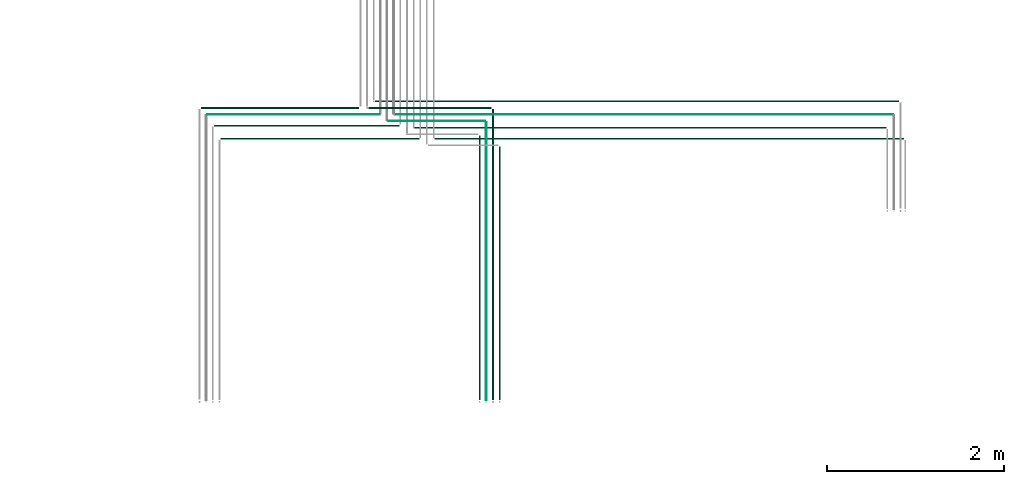
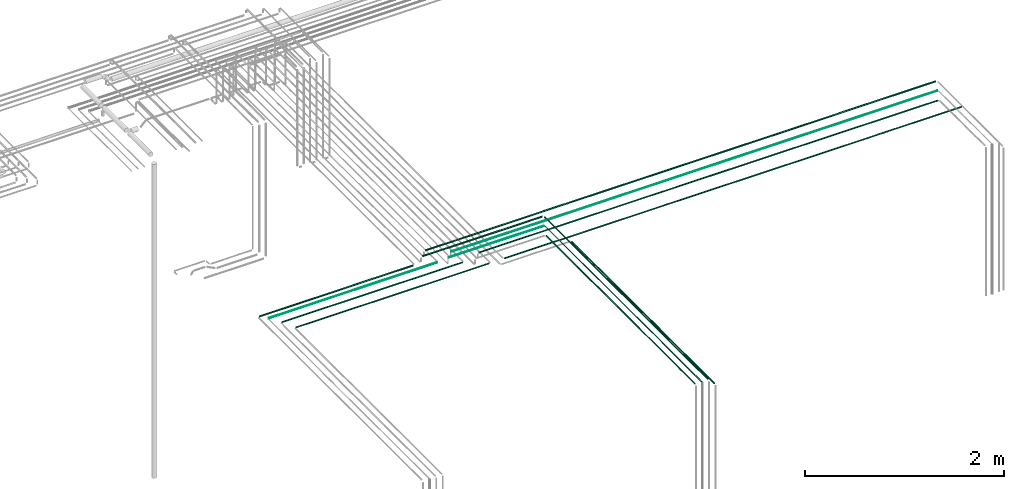
# One storey, part 22 of 65: 14 flow segments.
"""IFC2X3 building model written with IfcOpenShell, lengths in millimetres."""

from ifc_helpers import new_model, entity, si_unit, converted_unit, derived_unit, direction, frame, frame_2d, origin, origin_2d_with_axis, place, context, subcontext, project, spatial, circle, extrude, type_object, element, save


model = new_model("IFC2X3")

# Units and contexts
model_context = context("Model", 3, precision=0.01, world=origin(), true_north=direction((6.12303176911189e-17, 1.0)))
body_context = subcontext(model_context, "Body", "Model", "MODEL_VIEW")
ifc_project = project(units=[si_unit("LENGTHUNIT", "METRE", prefix="MILLI"), si_unit("AREAUNIT", "SQUARE_METRE"), si_unit("VOLUMEUNIT", "CUBIC_METRE"), converted_unit("PLANEANGLEUNIT", "DEGREE", entity("IfcRatioMeasure", 0.0174532925199433), si_unit("PLANEANGLEUNIT", "RADIAN"), dimensions=[0, 0, 0, 0, 0, 0, 0]), si_unit("MASSUNIT", "GRAM", prefix="KILO"), derived_unit("MASSDENSITYUNIT", [(si_unit("MASSUNIT", "GRAM", prefix="KILO"), 1), (si_unit("LENGTHUNIT", "METRE"), -3)]), derived_unit("MOMENTOFINERTIAUNIT", [(si_unit("LENGTHUNIT", "METRE"), 4)]), si_unit("TIMEUNIT", "SECOND"), si_unit("FREQUENCYUNIT", "HERTZ"), si_unit("THERMODYNAMICTEMPERATUREUNIT", "DEGREE_CELSIUS"), derived_unit("THERMALTRANSMITTANCEUNIT", [(si_unit("MASSUNIT", "GRAM", prefix="KILO"), 1), (si_unit("THERMODYNAMICTEMPERATUREUNIT", "KELVIN"), -1), (si_unit("TIMEUNIT", "SECOND"), -3)]), derived_unit("VOLUMETRICFLOWRATEUNIT", [(si_unit("LENGTHUNIT", "METRE"), 3), (si_unit("TIMEUNIT", "SECOND"), -1)]), derived_unit("MASSFLOWRATEUNIT", [(si_unit("MASSUNIT", "GRAM", prefix="KILO"), 1), (si_unit("TIMEUNIT", "SECOND"), -1)]), derived_unit("ROTATIONALFREQUENCYUNIT", [(si_unit("TIMEUNIT", "SECOND"), -1)]), si_unit("ELECTRICCURRENTUNIT", "AMPERE"), si_unit("ELECTRICVOLTAGEUNIT", "VOLT"), si_unit("POWERUNIT", "WATT"), si_unit("FORCEUNIT", "NEWTON", prefix="KILO"), si_unit("ILLUMINANCEUNIT", "LUX"), si_unit("LUMINOUSFLUXUNIT", "LUMEN"), si_unit("LUMINOUSINTENSITYUNIT", "CANDELA"), derived_unit("USERDEFINED", [(si_unit("MASSUNIT", "GRAM", prefix="KILO"), -1), (si_unit("LENGTHUNIT", "METRE"), -2), (si_unit("TIMEUNIT", "SECOND"), 3), (si_unit("LUMINOUSFLUXUNIT", "LUMEN"), 1)]), derived_unit("LINEARVELOCITYUNIT", [(si_unit("LENGTHUNIT", "METRE"), 1), (si_unit("TIMEUNIT", "SECOND"), -1)]), si_unit("PRESSUREUNIT", "PASCAL"), derived_unit("USERDEFINED", [(si_unit("LENGTHUNIT", "METRE"), -2), (si_unit("MASSUNIT", "GRAM", prefix="KILO"), 1), (si_unit("TIMEUNIT", "SECOND"), -2)]), derived_unit("LINEARFORCEUNIT", [(si_unit("MASSUNIT", "GRAM", prefix="KILO"), 1), (si_unit("LENGTHUNIT", "METRE"), 1), (si_unit("TIMEUNIT", "SECOND"), -2), (si_unit("LENGTHUNIT", "METRE"), -1)]), derived_unit("PLANARFORCEUNIT", [(si_unit("MASSUNIT", "GRAM", prefix="KILO"), 1), (si_unit("LENGTHUNIT", "METRE"), 1), (si_unit("TIMEUNIT", "SECOND"), -2), (si_unit("LENGTHUNIT", "METRE"), -2)])], contexts=[model_context])

# Site, building, storey
site_placement = place(None, frame((0.0, -0.00077364408347762, 0.0)))
site = spatial("IfcSite", under=ifc_project, at=site_placement, CompositionType="ELEMENT")
building_placement = place(site_placement, origin())
building = spatial("IfcBuilding", under=site, at=building_placement, CompositionType="ELEMENT")
storey_placement = place(building_placement, frame((0.0, 0.0, 19800.0)))
storey = spatial("IfcBuildingStorey", under=building, at=storey_placement, CompositionType="ELEMENT", Elevation=19800.0)

# Flow segments
pipe_segment_type = type_object("IfcPipeSegmentType", PredefinedType="NOTDEFINED")
flow_segment_1_placement = place(storey_placement, frame((64237.1498843194, 4080.31599040538, 3140.90472776409)))
element("IfcFlowSegment", 1, at=flow_segment_1_placement, inside=storey, type_object=pipe_segment_type, context=body_context, shape_type="SweptSolid", body=[
    extrude(circle(Radius=7.5, at=origin_2d_with_axis()), frame((0.0, 9.0952722359234, 9.09527223591419), z_axis=(1.0, 0.0, 0.0), x_axis=(0.0, -1.0, 0.0)), (0.0, 0.0, 1.0), 1779.96199895821),
])
flow_segment_2_placement = place(storey_placement, frame((66874.1118832777, 3732.83013468698, 3142.40472776415)))
element("IfcFlowSegment", 2, at=flow_segment_2_placement, inside=storey, type_object=pipe_segment_type, context=body_context, shape_type="SweptSolid", body=[
    extrude(circle(Radius=6.0, at=frame_2d((4.33146851719357e-12, 0.0), x_axis=(1.0, 0.0))), frame((0.0, 7.59527223592049, 7.59527223591454), z_axis=(1.0, 0.0, 0.0), x_axis=(0.0, 1.0, 0.0)), (0.0, 0.0, 1.0), 5294.03800104174),
])
flow_segment_3_placement = place(storey_placement, frame((66203.1118832776, 4155.31599040536, 3215.90472776409)))
element("IfcFlowSegment", 3, at=flow_segment_3_placement, inside=storey, type_object=pipe_segment_type, context=body_context, shape_type="SweptSolid", body=[
    extrude(circle(Radius=7.5, at=frame_2d((1.29944055515807e-11, 0.0), x_axis=(1.0, 0.0))), frame((0.0, 9.09527223592881, 9.09527223591419), z_axis=(1.0, 0.0, 0.0), x_axis=(0.0, 1.0, 0.0)), (0.0, 0.0, 1.0), 5908.28250962337),
])
flow_segment_4_placement = place(storey_placement, frame((66128.1118832776, 4080.31599040536, 3215.90472776409)))
element("IfcFlowSegment", 4, at=flow_segment_4_placement, inside=storey, type_object=pipe_segment_type, context=body_context, shape_type="SweptSolid", body=[
    extrude(circle(Radius=7.5, at=frame_2d((8.12150346973795e-12, 0.0), x_axis=(1.0, 0.0))), frame((0.0, 9.09527223592394, 9.09527223591419), z_axis=(1.0, 0.0, 0.0), x_axis=(0.0, 1.0, 0.0)), (0.0, 0.0, 1.0), 1383.28250962336),
])
flow_segment_5_placement = place(storey_placement, frame((67520.2991206651, 794.55544271603, 3215.90472776409)))
element("IfcFlowSegment", 5, at=flow_segment_5_placement, inside=storey, type_object=pipe_segment_type, context=body_context, shape_type="SweptSolid", body=[
    extrude(circle(Radius=7.5, at=frame_2d((8.66293703438714e-12, 0.0), x_axis=(1.0, 0.0))), frame((9.09527223592286, 0.0, 9.09527223591419), z_axis=(0.0, 1.0, 0.0), x_axis=(-1.0, 0.0, 0.0)), (0.0, 0.0, 1.0), 3276.85581992526),
])
flow_segment_6_placement = place(storey_placement, frame((64304.1498843194, 4008.81599040537, 3144.40472776408)))
element("IfcFlowSegment", 6, at=flow_segment_6_placement, inside=storey, type_object=pipe_segment_type, context=body_context, shape_type="SweptSolid", body=[
    extrude(circle(Radius=4.0, at=frame_2d((-7.58006990508875e-12, 0.0), x_axis=(1.0, 0.0))), frame((0.0, 5.59527223592365, 5.59527223591499), z_axis=(1.0, 0.0, 0.0), x_axis=(0.0, 1.0, 0.0)), (0.0, 0.0, 1.0), 1945.96199895822),
])
flow_segment_7_placement = place(storey_placement, frame((66420.1118832776, 4008.81599040536, 3219.40472776408)))
element("IfcFlowSegment", 7, at=flow_segment_7_placement, inside=storey, type_object=pipe_segment_type, context=body_context, shape_type="SweptSolid", body=[
    extrude(circle(Radius=4.0, at=frame_2d((1.57015733748267e-11, 0.0), x_axis=(1.0, 0.0))), frame((0.0, 5.59527223593178, 5.59527223591499), z_axis=(1.0, 0.0, 0.0), x_axis=(0.0, 1.0, 0.0)), (0.0, 0.0, 1.0), 5624.28250962336),
])
flow_segment_8_placement = place(storey_placement, frame((66345.1118832776, 3933.81599040536, 3219.40472776409)))
element("IfcFlowSegment", 8, at=flow_segment_8_placement, inside=storey, type_object=pipe_segment_type, context=body_context, shape_type="SweptSolid", body=[
    extrude(circle(Radius=4.0, at=frame_2d((1.08286712929839e-11, 0.0), x_axis=(1.0, 0.0))), frame((0.0, 5.59527223592636, 5.59527223591499), z_axis=(1.0, 0.0, 0.0), x_axis=(0.0, 1.0, 0.0)), (0.0, 0.0, 1.0), 1099.28250962337),
])
flow_segment_9_placement = place(storey_placement, frame((67448.7991206651, 788.555442716031, 3219.40472776409)))
element("IfcFlowSegment", 9, at=flow_segment_9_placement, inside=storey, type_object=pipe_segment_type, context=body_context, shape_type="SweptSolid", body=[
    extrude(circle(Radius=4.0, at=frame_2d((8.66293703438714e-12, 0.0), x_axis=(1.0, 0.0))), frame((5.59527223592365, 0.0, 5.59527223591499), z_axis=(0.0, 1.0, 0.0), x_axis=(-1.0, 0.0, 0.0)), (0.0, 0.0, 1.0), 3140.85581992527),
])
flow_segment_10_placement = place(storey_placement, frame((66649.1118832777, 3856.81599040537, 3217.40472776409)))
element("IfcFlowSegment", 10, at=flow_segment_10_placement, inside=storey, type_object=pipe_segment_type, context=body_context, shape_type="SweptSolid", body=[
    extrude(circle(Radius=6.0, at=frame_2d((1.84087411980727e-11, 0.0), x_axis=(1.0, 0.0))), frame((0.0, 7.59527223593457, 7.59527223591454), z_axis=(1.0, 0.0, 0.0), x_axis=(0.0, 1.0, 0.0)), (0.0, 0.0, 1.0), 5316.2825096233),
])
flow_segment_11_placement = place(storey_placement, frame((67371.7991206651, 794.55544271603, 3217.40472776409)))
element("IfcFlowSegment", 11, at=flow_segment_11_placement, inside=storey, type_object=pipe_segment_type, context=body_context, shape_type="SweptSolid", body=[
    extrude(circle(Radius=6.0, at=frame_2d((8.66293703438714e-12, 0.0), x_axis=(1.0, 0.0))), frame((7.59527223593186, 0.0, 7.59527223591454), z_axis=(0.0, 1.0, 0.0), x_axis=(-1.0, 0.0, 0.0)), (0.0, 0.0, 1.0), 2980.85581992527),
])
flow_segment_12_placement = place(storey_placement, frame((64383.1498843194, 3881.81599040537, 3142.40472776409)))
element("IfcFlowSegment", 12, at=flow_segment_12_placement, inside=storey, type_object=pipe_segment_type, context=body_context, shape_type="SweptSolid", body=[
    extrude(circle(Radius=6.0, at=frame_2d((-1.19115384222823e-11, 0.0), x_axis=(1.0, 0.0))), frame((0.0, 7.59527223592753, 7.59527223591454), z_axis=(1.0, 0.0, 0.0), x_axis=(0.0, 1.0, 0.0)), (0.0, 0.0, 1.0), 2087.96199895853),
])
flow_segment_13_placement = place(storey_placement, frame((64458.1498843194, 3731.81599040536, 3142.40472776409)))
element("IfcFlowSegment", 13, at=flow_segment_13_placement, inside=storey, type_object=pipe_segment_type, context=body_context, shape_type="SweptSolid", body=[
    extrude(circle(Radius=6.0, at=frame_2d((-1.57015733748267e-11, 0.0), x_axis=(1.0, 0.0))), frame((0.0, 7.59527223593186, 7.59527223591454), z_axis=(1.0, 0.0, 0.0), x_axis=(0.0, 1.0, 0.0)), (0.0, 0.0, 1.0), 2237.96199895854),
])
flow_segment_14_placement = place(storey_placement, frame((67596.7991206651, 794.55544271603, 3142.40472776406)))
element("IfcFlowSegment", 14, at=flow_segment_14_placement, inside=storey, type_object=pipe_segment_type, context=body_context, shape_type="SweptSolid", body=[
    extrude(circle(Radius=6.0, at=frame_2d((8.66293703438714e-12, 0.0), x_axis=(1.0, 0.0))), frame((7.5952722359232, 0.0, 7.59527223591454), z_axis=(0.0, 1.0, 0.0), x_axis=(-1.0, 0.0, 0.0)), (0.0, 0.0, 1.0), 2856.86996420687),
])

save(model, "model.ifc")
